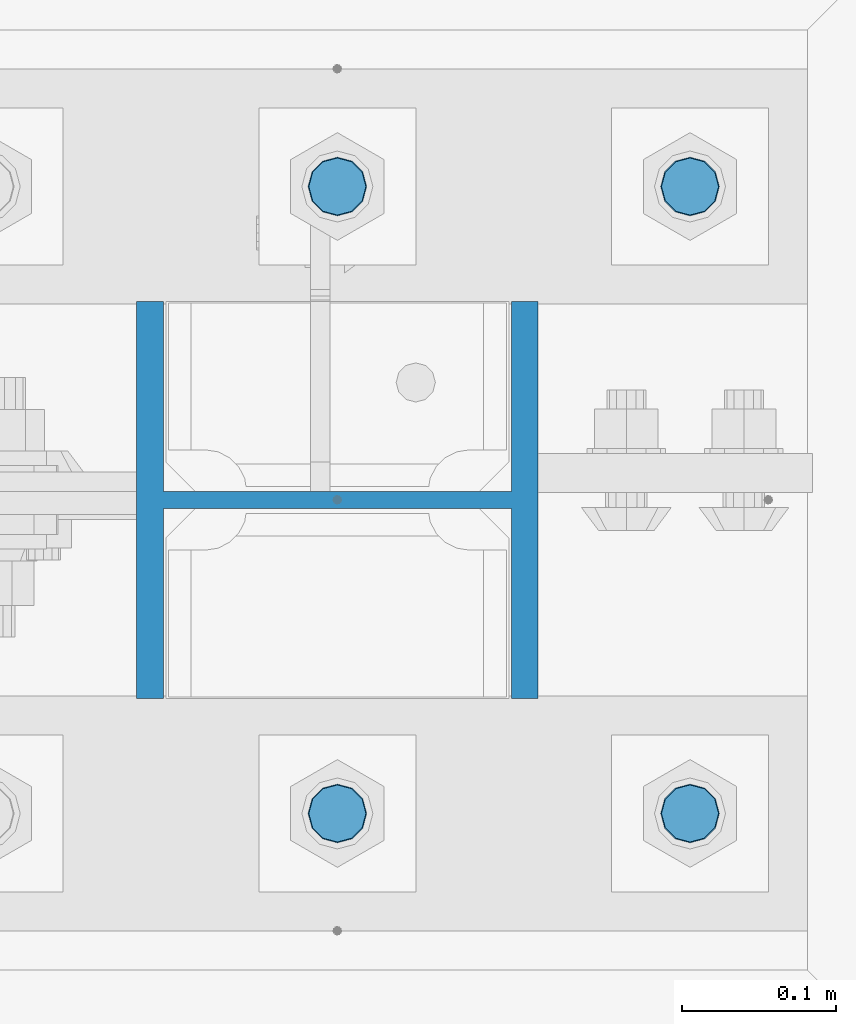
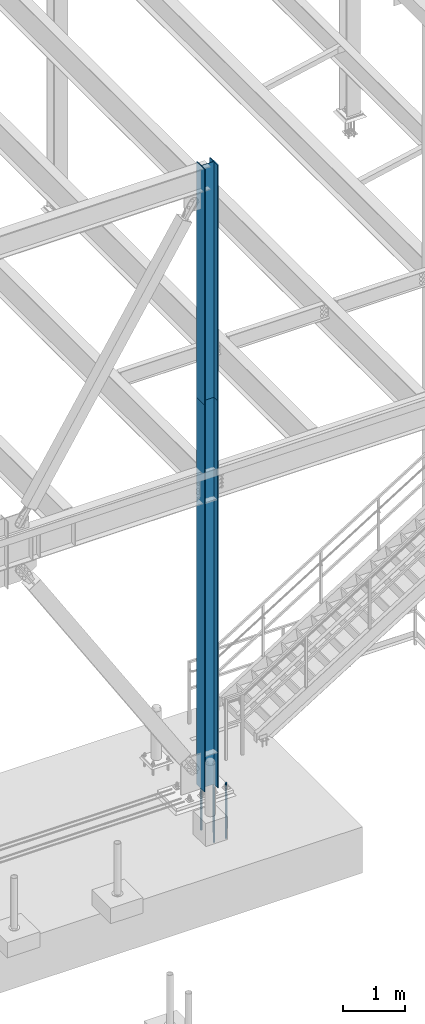
# One storey, part 1366 of 3843: 6 columns, 3 elements without a shape of their own.
"""IFC2X3 building model written with IfcOpenShell, lengths in millimetres."""

from ifc_helpers import new_model, si_unit, frame, origin_with_axes, place, context, subcontext, project, spatial, faceted_brep, material, type_object, element, aggregate, save


model = new_model("IFC2X3")

# Units and contexts
model_context = context("Model", 3, precision=1e-05, world=origin_with_axes())
body_context = subcontext(model_context, "Body", "Model", "MODEL_VIEW")
ifc_project = project(units=[si_unit("LENGTHUNIT", "METRE", prefix="MILLI"), si_unit("AREAUNIT", "SQUARE_METRE"), si_unit("VOLUMEUNIT", "CUBIC_METRE"), si_unit("MASSUNIT", "GRAM", prefix="KILO"), si_unit("TIMEUNIT", "SECOND"), si_unit("PLANEANGLEUNIT", "RADIAN"), si_unit("SOLIDANGLEUNIT", "STERADIAN"), si_unit("THERMODYNAMICTEMPERATUREUNIT", "DEGREE_CELSIUS"), si_unit("LUMINOUSINTENSITYUNIT", "LUMEN")], contexts=[model_context])

# Site, building, storey
site_placement = place(None, origin_with_axes())
site = spatial("IfcSite", under=ifc_project, at=site_placement, CompositionType="ELEMENT")
building_placement = place(site_placement, origin_with_axes())
building = spatial("IfcBuilding", under=site, at=building_placement, Name="Undefined", CompositionType="ELEMENT")
storey_placement = place(building_placement, origin_with_axes())
storey = spatial("IfcBuildingStorey", under=building, at=storey_placement, Name="Undefined", CompositionType="ELEMENT", Elevation=0.0)

# Assembly, column
assembly_1_placement = place(storey_placement, origin_with_axes())
assembly_1 = element("IfcElementAssembly", 1, at=assembly_1_placement, inside=storey, Name="CB", AssemblyPlace="NOTDEFINED", PredefinedType="RIGID_FRAME")
ifc_material_1 = material(Name="STEEL/A992")
column_type_1 = type_object("IfcColumnType", Name="W10X60", PredefinedType="NOTDEFINED")
column_1_placement = place(assembly_1_placement, frame((30480.0, 89115.9, 37795.2), z_axis=(-1.0, 0.0, 0.0), x_axis=(0.0, 0.0, 1.0)))
column_1 = element("IfcColumn", 2, at=column_1_placement, type_object=column_type_1, material=ifc_material_1, Name="COLUMN", ObjectType="W10X60", context=body_context, shape_type="Brep", body=[
    faceted_brep([(0.0, 128.587499999994, -130.174999999999), (0.0, 128.587499999994, -112.712500000001), (4673.60000000001, 128.587499999994, -112.712500000001), (4673.60000000001, 128.587499999994, -130.174999999999), (0.0, 5.55624999999418, -112.712500000001), (4673.60000000001, 5.55624999999418, -112.712500000001), (0.0, 5.55624999999418, 112.712500000001), (4673.60000000001, 5.55624999999418, 112.712500000001), (0.0, 128.587499999994, 112.712500000001), (4673.60000000001, 128.587499999994, 112.712500000001), (0.0, 128.587499999994, 130.174999999999), (4673.60000000001, 128.587499999994, 130.174999999999), (0.0, -128.587499999994, 130.174999999999), (4673.60000000001, -128.587499999994, 130.174999999999), (0.0, -128.587499999994, 112.712500000001), (4673.60000000001, -128.587499999994, 112.712500000001), (0.0, -5.55624999999418, 112.712500000001), (4673.60000000001, -5.55624999999418, 112.712500000001), (0.0, -5.55624999999418, -112.712500000001), (4673.60000000001, -5.55624999999418, -112.712500000001), (0.0, -128.587499999994, -112.712500000001), (4673.60000000001, -128.587499999994, -112.712500000001), (0.0, -128.587499999994, -130.174999999999), (4673.60000000001, -128.587499999994, -130.174999999999)], [[[0, 1, 2, 3]], [[1, 4, 5, 2]], [[4, 6, 7, 5]], [[6, 8, 9, 7]], [[8, 10, 11, 9]], [[10, 12, 13, 11]], [[12, 14, 15, 13]], [[14, 16, 17, 15]], [[16, 18, 19, 17]], [[18, 20, 21, 19]], [[20, 22, 23, 21]], [[22, 0, 3, 23]], [[5, 7, 9, 11, 13, 15, 17, 19, 21, 23, 3, 2]], [[22, 20, 18, 16, 14, 12, 10, 8, 6, 4, 1, 0]]]),
])
aggregate(assembly_1, [column_1])

assembly_2_placement = place(storey_placement, origin_with_axes())
assembly_2 = element("IfcElementAssembly", 3, at=assembly_2_placement, inside=storey, Name="COLUMN", AssemblyPlace="NOTDEFINED", PredefinedType="RIGID_FRAME")
column_2_placement = place(assembly_2_placement, frame((30480.0, 89115.9, 30022.8), z_axis=(-1.0, 0.0, 0.0), x_axis=(0.0, 0.0, 1.0)))
column_2 = element("IfcColumn", 4, at=column_2_placement, type_object=column_type_1, material=ifc_material_1, Name="COLUMN", ObjectType="W10X60", context=body_context, shape_type="Brep", body=[
    faceted_brep([(101.599999999999, 128.587499999994, -130.174999999999), (101.599999999999, 128.587499999994, -112.712500000001), (7772.4, 128.587499999994, -112.712500000001), (7772.4, 128.587499999994, -130.174999999999), (101.599999999999, 5.55624999999418, -112.712500000001), (7772.4, 5.55624999999418, -112.712500000001), (101.599999999999, 5.55624999999418, 112.712500000001), (7772.4, 5.55624999999418, 112.712500000001), (101.599999999999, 128.587499999994, 112.712500000001), (7772.4, 128.587499999994, 112.712500000001), (101.599999999999, 128.587499999994, 130.174999999999), (7772.4, 128.587499999994, 130.174999999999), (101.599999999999, -128.587499999994, 130.174999999999), (7772.4, -128.587499999994, 130.174999999999), (101.599999999999, -128.587499999994, 112.712500000001), (7772.4, -128.587499999994, 112.712500000001), (101.599999999999, -5.55624999999418, 112.712500000001), (7772.4, -5.55624999999418, 112.712500000001), (101.599999999999, -5.55624999999418, -112.712500000001), (7772.4, -5.55624999999418, -112.712500000001), (101.599999999999, -128.587499999994, -112.712500000001), (7772.4, -128.587499999994, -112.712500000001), (101.599999999999, -128.587499999994, -130.174999999999), (7772.4, -128.587499999994, -130.174999999999)], [[[0, 1, 2, 3]], [[1, 4, 5, 2]], [[4, 6, 7, 5]], [[6, 8, 9, 7]], [[8, 10, 11, 9]], [[10, 12, 13, 11]], [[12, 14, 15, 13]], [[14, 16, 17, 15]], [[16, 18, 19, 17]], [[18, 20, 21, 19]], [[20, 22, 23, 21]], [[22, 0, 3, 23]], [[5, 7, 9, 11, 13, 15, 17, 19, 21, 23, 3, 2]], [[22, 20, 18, 16, 14, 12, 10, 8, 6, 4, 1, 0]]]),
])
aggregate(assembly_2, [column_2])

# Assembly, columns
assembly_3_placement = place(storey_placement, origin_with_axes())
assembly_3 = element("IfcElementAssembly", 5, at=assembly_3_placement, inside=storey, Name="TEMPLATE", AssemblyPlace="NOTDEFINED", PredefinedType="RIGID_FRAME")
ifc_material_2 = material(Name="Undefined/F1554-GR.55")
column_type_2 = type_object("IfcColumnType", PredefinedType="NOTDEFINED")
column_3_placement = place(assembly_3_placement, frame((30708.6, 88912.7, 30022.8), z_axis=(1.0, 0.0, 0.0), x_axis=(0.0, 0.0, -1.0)))
column_3 = element("IfcColumn", 6, at=column_3_placement, type_object=column_type_2, material=ifc_material_2, Name="ANCHOR_ROD", context=body_context, shape_type="Brep", body=[
    faceted_brep([(-209.549999999999, -16.0214699700155, 9.25), (-209.549999999999, -9.25, 16.0214699700118), (-209.549999999999, 0.0, 18.5), (-209.549999999999, 9.25, 16.0214699700118), (-209.549999999999, 16.0214699700155, 9.25), (-209.549999999999, 18.5, 0.0), (-209.549999999999, 16.0214699700155, -9.25), (-209.549999999999, 9.25, -16.0214699700118), (-209.549999999999, 0.0, -18.5), (-209.549999999999, -9.25, -16.0214699700118), (-209.549999999999, -16.0214699700155, -9.25), (-209.549999999999, -18.5, 0.0), (0.0, 18.5, 0.0), (0.0, 16.0214699700118, -9.25), (0.0, 9.25, -16.0214699700155), (0.0, 0.0, -18.5), (0.0, -9.25, -16.0214699700155), (0.0, -16.0214699700118, -9.25), (0.0, -18.5, 0.0), (0.0, -16.0214699700118, 9.25), (0.0, -9.25, 16.0214699700155), (0.0, 0.0, 18.5), (0.0, 9.25, 16.0214699700155), (0.0, 16.0214699700118, 9.25), (0.0, -16.4977839420972, 9.52500000000146), (0.0, -9.52500000000146, 16.4977839420972), (0.0, 0.0, 19.0499989999989), (0.0, 9.52500000000146, 16.4977839420972), (0.0, 16.4977839420972, 9.52500000000146), (0.0, 19.0500000000029, 0.0), (0.0, 16.4977839420972, -9.52500000000146), (0.0, 9.52500000000146, -16.4977839420972), (0.0, 0.0, -19.0499989999989), (0.0, -9.52500000000146, -16.4977839420972), (0.0, -16.4977839420972, -9.52500000000146), (0.0, -19.0500000000029, 0.0), (698.5, -19.0499999999993, 0.0), (698.5, -16.4977839420935, 9.52499999999418), (698.5, -9.52500000000146, 16.4977839420899), (698.5, 0.0, 19.0500000000029), (698.5, 9.52500000000146, 16.4977839420899), (698.5, 16.4977839420935, 9.52499999999418), (698.5, 19.0499999999993, 0.0), (698.5, 16.4977839420935, -9.52499999999418), (698.5, 9.52500000000146, -16.4977839420899), (698.5, 0.0, -19.0500000000029), (698.5, -9.52500000000146, -16.4977839420899), (698.5, -16.4977839420935, -9.52499999999418), (698.5, -9.25, 16.0214699700155), (698.5, 0.0, 18.5), (698.5, 9.25, 16.0214699700155), (698.5, 16.0214699700118, 9.25), (698.5, 18.5, 0.0), (698.5, 16.0214699700118, -9.25), (698.5, 9.25, -16.0214699700155), (698.5, 0.0, -18.5), (698.5, -9.25, -16.0214699700155), (698.5, -16.0214699700118, -9.25), (698.5, -18.5, 0.0), (698.5, -16.0214699700118, 9.25), (889.0, -9.25, -16.0214699700155), (889.0, 0.0, -18.5), (889.0, 9.25, -16.0214699700155), (889.0, 16.0214699700118, -9.25), (889.0, 18.5, 0.0), (889.0, 16.0214699700118, 9.25), (889.0, 9.25, 16.0214699700155), (889.0, 0.0, 18.5), (889.0, -9.25, 16.0214699700155), (889.0, -16.0214699700118, 9.25), (889.0, -18.5, 0.0), (889.0, -16.0214699700118, -9.25)], [[[0, 1, 2, 3, 4, 5, 6, 7, 8, 9, 10, 11]], [[6, 5, 12, 13]], [[7, 6, 13, 14]], [[8, 7, 14, 15]], [[9, 8, 15, 16]], [[10, 9, 16, 17]], [[11, 10, 17, 18]], [[0, 11, 18, 19]], [[1, 0, 19, 20]], [[2, 1, 20, 21]], [[3, 2, 21, 22]], [[4, 3, 22, 23]], [[5, 4, 23, 12]], [[24, 25, 26, 27, 28, 29, 30, 31, 32, 33, 34, 35], [22, 21, 20, 19, 18, 17, 16, 15, 14, 13, 12, 23]], [[24, 35, 36, 37]], [[25, 24, 37, 38]], [[26, 25, 38, 39]], [[27, 26, 39, 40]], [[28, 27, 40, 41]], [[29, 28, 41, 42]], [[30, 29, 42, 43]], [[31, 30, 43, 44]], [[32, 31, 44, 45]], [[33, 32, 45, 46]], [[34, 33, 46, 47]], [[35, 34, 47, 36]], [[46, 45, 44, 43, 42, 41, 40, 39, 38, 37, 36, 47], [48, 49, 50, 51, 52, 53, 54, 55, 56, 57, 58, 59]], [[60, 61, 62, 63, 64, 65, 66, 67, 68, 69, 70, 71]], [[68, 67, 49, 48]], [[69, 68, 48, 59]], [[70, 69, 59, 58]], [[71, 70, 58, 57]], [[60, 71, 57, 56]], [[61, 60, 56, 55]], [[62, 61, 55, 54]], [[63, 62, 54, 53]], [[64, 63, 53, 52]], [[65, 64, 52, 51]], [[66, 65, 51, 50]], [[67, 66, 50, 49]]]),
])
column_4_placement = place(assembly_3_placement, frame((30708.6, 89319.1, 30022.8), z_axis=(-1.0, 0.0, 0.0), x_axis=(0.0, 0.0, -1.0)))
column_4 = element("IfcColumn", 7, at=column_4_placement, type_object=column_type_2, material=ifc_material_2, Name="ANCHOR_ROD", context=body_context, shape_type="Brep", body=[
    faceted_brep([(-209.549999999999, -16.0214699700155, 9.25), (-209.549999999999, -9.25, 16.0214699700118), (-209.549999999999, 0.0, 18.5), (-209.549999999999, 9.25, 16.0214699700118), (-209.549999999999, 16.0214699700155, 9.25), (-209.549999999999, 18.5, 0.0), (-209.549999999999, 16.0214699700155, -9.25), (-209.549999999999, 9.25, -16.0214699700118), (-209.549999999999, 0.0, -18.5), (-209.549999999999, -9.25, -16.0214699700118), (-209.549999999999, -16.0214699700155, -9.25), (-209.549999999999, -18.5, 0.0), (0.0, 18.5, 0.0), (0.0, 16.0214699700118, -9.25), (0.0, 9.25, -16.0214699700155), (0.0, 0.0, -18.5), (0.0, -9.25, -16.0214699700155), (0.0, -16.0214699700118, -9.25), (0.0, -18.5, 0.0), (0.0, -16.0214699700118, 9.25), (0.0, -9.25, 16.0214699700155), (0.0, 0.0, 18.5), (0.0, 9.25, 16.0214699700155), (0.0, 16.0214699700118, 9.25), (0.0, -16.4977839420972, 9.52500000000146), (0.0, -9.52500000000146, 16.4977839420972), (0.0, 0.0, 19.0499989999989), (0.0, 9.52500000000146, 16.4977839420972), (0.0, 16.4977839420972, 9.52500000000146), (0.0, 19.0500000000029, 0.0), (0.0, 16.4977839420972, -9.52500000000146), (0.0, 9.52500000000146, -16.4977839420972), (0.0, 0.0, -19.0499989999989), (0.0, -9.52500000000146, -16.4977839420972), (0.0, -16.4977839420972, -9.52500000000146), (0.0, -19.0500000000029, 0.0), (698.5, -19.0499999999993, 0.0), (698.5, -16.4977839420935, 9.52499999999418), (698.5, -9.52500000000146, 16.4977839420899), (698.5, 0.0, 19.0500000000029), (698.5, 9.52500000000146, 16.4977839420899), (698.5, 16.4977839420935, 9.52499999999418), (698.5, 19.0499999999993, 0.0), (698.5, 16.4977839420935, -9.52499999999418), (698.5, 9.52500000000146, -16.4977839420899), (698.5, 0.0, -19.0500000000029), (698.5, -9.52500000000146, -16.4977839420899), (698.5, -16.4977839420935, -9.52499999999418), (698.5, -9.25, 16.0214699700155), (698.5, 0.0, 18.5), (698.5, 9.25, 16.0214699700155), (698.5, 16.0214699700118, 9.25), (698.5, 18.5, 0.0), (698.5, 16.0214699700118, -9.25), (698.5, 9.25, -16.0214699700155), (698.5, 0.0, -18.5), (698.5, -9.25, -16.0214699700155), (698.5, -16.0214699700118, -9.25), (698.5, -18.5, 0.0), (698.5, -16.0214699700118, 9.25), (889.0, -9.25, -16.0214699700155), (889.0, 0.0, -18.5), (889.0, 9.25, -16.0214699700155), (889.0, 16.0214699700118, -9.25), (889.0, 18.5, 0.0), (889.0, 16.0214699700118, 9.25), (889.0, 9.25, 16.0214699700155), (889.0, 0.0, 18.5), (889.0, -9.25, 16.0214699700155), (889.0, -16.0214699700118, 9.25), (889.0, -18.5, 0.0), (889.0, -16.0214699700118, -9.25)], [[[0, 1, 2, 3, 4, 5, 6, 7, 8, 9, 10, 11]], [[6, 5, 12, 13]], [[7, 6, 13, 14]], [[8, 7, 14, 15]], [[9, 8, 15, 16]], [[10, 9, 16, 17]], [[11, 10, 17, 18]], [[0, 11, 18, 19]], [[1, 0, 19, 20]], [[2, 1, 20, 21]], [[3, 2, 21, 22]], [[4, 3, 22, 23]], [[5, 4, 23, 12]], [[24, 25, 26, 27, 28, 29, 30, 31, 32, 33, 34, 35], [22, 21, 20, 19, 18, 17, 16, 15, 14, 13, 12, 23]], [[24, 35, 36, 37]], [[25, 24, 37, 38]], [[26, 25, 38, 39]], [[27, 26, 39, 40]], [[28, 27, 40, 41]], [[29, 28, 41, 42]], [[30, 29, 42, 43]], [[31, 30, 43, 44]], [[32, 31, 44, 45]], [[33, 32, 45, 46]], [[34, 33, 46, 47]], [[35, 34, 47, 36]], [[46, 45, 44, 43, 42, 41, 40, 39, 38, 37, 36, 47], [48, 49, 50, 51, 52, 53, 54, 55, 56, 57, 58, 59]], [[60, 61, 62, 63, 64, 65, 66, 67, 68, 69, 70, 71]], [[68, 67, 49, 48]], [[69, 68, 48, 59]], [[70, 69, 59, 58]], [[71, 70, 58, 57]], [[60, 71, 57, 56]], [[61, 60, 56, 55]], [[62, 61, 55, 54]], [[63, 62, 54, 53]], [[64, 63, 53, 52]], [[65, 64, 52, 51]], [[66, 65, 51, 50]], [[67, 66, 50, 49]]]),
])
column_5_placement = place(assembly_3_placement, frame((30480.0, 88912.7, 30022.8), z_axis=(1.0, 0.0, 0.0), x_axis=(0.0, 0.0, -1.0)))
column_5 = element("IfcColumn", 8, at=column_5_placement, type_object=column_type_2, material=ifc_material_2, Name="ANCHOR_ROD", context=body_context, shape_type="Brep", body=[
    faceted_brep([(-209.549999999999, -16.0214699700155, 9.25), (-209.549999999999, -9.25, 16.0214699700118), (-209.549999999999, 0.0, 18.5), (-209.549999999999, 9.25, 16.0214699700118), (-209.549999999999, 16.0214699700155, 9.25), (-209.549999999999, 18.5, 0.0), (-209.549999999999, 16.0214699700155, -9.25), (-209.549999999999, 9.25, -16.0214699700118), (-209.549999999999, 0.0, -18.5), (-209.549999999999, -9.25, -16.0214699700118), (-209.549999999999, -16.0214699700155, -9.25), (-209.549999999999, -18.5, 0.0), (0.0, 18.5, 0.0), (0.0, 16.0214699700118, -9.25), (0.0, 9.25, -16.0214699700155), (0.0, 0.0, -18.5), (0.0, -9.25, -16.0214699700155), (0.0, -16.0214699700118, -9.25), (0.0, -18.5, 0.0), (0.0, -16.0214699700118, 9.25), (0.0, -9.25, 16.0214699700155), (0.0, 0.0, 18.5), (0.0, 9.25, 16.0214699700155), (0.0, 16.0214699700118, 9.25), (0.0, -16.4977839420972, 9.52500000000146), (0.0, -9.52500000000146, 16.4977839420972), (0.0, 0.0, 19.0499989999989), (0.0, 9.52500000000146, 16.4977839420972), (0.0, 16.4977839420972, 9.52500000000146), (0.0, 19.0500000000029, 0.0), (0.0, 16.4977839420972, -9.52500000000146), (0.0, 9.52500000000146, -16.4977839420972), (0.0, 0.0, -19.0499989999989), (0.0, -9.52500000000146, -16.4977839420972), (0.0, -16.4977839420972, -9.52500000000146), (0.0, -19.0500000000029, 0.0), (698.5, -19.0499999999993, 0.0), (698.5, -16.4977839420935, 9.52499999999418), (698.5, -9.52500000000146, 16.4977839420899), (698.5, 0.0, 19.0500000000029), (698.5, 9.52500000000146, 16.4977839420899), (698.5, 16.4977839420935, 9.52499999999418), (698.5, 19.0499999999993, 0.0), (698.5, 16.4977839420935, -9.52499999999418), (698.5, 9.52500000000146, -16.4977839420899), (698.5, 0.0, -19.0500000000029), (698.5, -9.52500000000146, -16.4977839420899), (698.5, -16.4977839420935, -9.52499999999418), (698.5, -9.25, 16.0214699700155), (698.5, 0.0, 18.5), (698.5, 9.25, 16.0214699700155), (698.5, 16.0214699700118, 9.25), (698.5, 18.5, 0.0), (698.5, 16.0214699700118, -9.25), (698.5, 9.25, -16.0214699700155), (698.5, 0.0, -18.5), (698.5, -9.25, -16.0214699700155), (698.5, -16.0214699700118, -9.25), (698.5, -18.5, 0.0), (698.5, -16.0214699700118, 9.25), (889.0, -9.25, -16.0214699700155), (889.0, 0.0, -18.5), (889.0, 9.25, -16.0214699700155), (889.0, 16.0214699700118, -9.25), (889.0, 18.5, 0.0), (889.0, 16.0214699700118, 9.25), (889.0, 9.25, 16.0214699700155), (889.0, 0.0, 18.5), (889.0, -9.25, 16.0214699700155), (889.0, -16.0214699700118, 9.25), (889.0, -18.5, 0.0), (889.0, -16.0214699700118, -9.25)], [[[0, 1, 2, 3, 4, 5, 6, 7, 8, 9, 10, 11]], [[6, 5, 12, 13]], [[7, 6, 13, 14]], [[8, 7, 14, 15]], [[9, 8, 15, 16]], [[10, 9, 16, 17]], [[11, 10, 17, 18]], [[0, 11, 18, 19]], [[1, 0, 19, 20]], [[2, 1, 20, 21]], [[3, 2, 21, 22]], [[4, 3, 22, 23]], [[5, 4, 23, 12]], [[24, 25, 26, 27, 28, 29, 30, 31, 32, 33, 34, 35], [22, 21, 20, 19, 18, 17, 16, 15, 14, 13, 12, 23]], [[24, 35, 36, 37]], [[25, 24, 37, 38]], [[26, 25, 38, 39]], [[27, 26, 39, 40]], [[28, 27, 40, 41]], [[29, 28, 41, 42]], [[30, 29, 42, 43]], [[31, 30, 43, 44]], [[32, 31, 44, 45]], [[33, 32, 45, 46]], [[34, 33, 46, 47]], [[35, 34, 47, 36]], [[46, 45, 44, 43, 42, 41, 40, 39, 38, 37, 36, 47], [48, 49, 50, 51, 52, 53, 54, 55, 56, 57, 58, 59]], [[60, 61, 62, 63, 64, 65, 66, 67, 68, 69, 70, 71]], [[68, 67, 49, 48]], [[69, 68, 48, 59]], [[70, 69, 59, 58]], [[71, 70, 58, 57]], [[60, 71, 57, 56]], [[61, 60, 56, 55]], [[62, 61, 55, 54]], [[63, 62, 54, 53]], [[64, 63, 53, 52]], [[65, 64, 52, 51]], [[66, 65, 51, 50]], [[67, 66, 50, 49]]]),
])
column_6_placement = place(assembly_3_placement, frame((30480.0, 89319.1, 30022.8), z_axis=(-1.0, 0.0, 0.0), x_axis=(0.0, 0.0, -1.0)))
column_6 = element("IfcColumn", 9, at=column_6_placement, type_object=column_type_2, material=ifc_material_2, Name="ANCHOR_ROD", context=body_context, shape_type="Brep", body=[
    faceted_brep([(-209.549999999999, -16.0214699700155, 9.25), (-209.549999999999, -9.25, 16.0214699700118), (-209.549999999999, 0.0, 18.5), (-209.549999999999, 9.25, 16.0214699700118), (-209.549999999999, 16.0214699700155, 9.25), (-209.549999999999, 18.5, 0.0), (-209.549999999999, 16.0214699700155, -9.25), (-209.549999999999, 9.25, -16.0214699700118), (-209.549999999999, 0.0, -18.5), (-209.549999999999, -9.25, -16.0214699700118), (-209.549999999999, -16.0214699700155, -9.25), (-209.549999999999, -18.5, 0.0), (0.0, 18.5, 0.0), (0.0, 16.0214699700118, -9.25), (0.0, 9.25, -16.0214699700155), (0.0, 0.0, -18.5), (0.0, -9.25, -16.0214699700155), (0.0, -16.0214699700118, -9.25), (0.0, -18.5, 0.0), (0.0, -16.0214699700118, 9.25), (0.0, -9.25, 16.0214699700155), (0.0, 0.0, 18.5), (0.0, 9.25, 16.0214699700155), (0.0, 16.0214699700118, 9.25), (0.0, -16.4977839420972, 9.52500000000146), (0.0, -9.52500000000146, 16.4977839420972), (0.0, 0.0, 19.0499989999989), (0.0, 9.52500000000146, 16.4977839420972), (0.0, 16.4977839420972, 9.52500000000146), (0.0, 19.0500000000029, 0.0), (0.0, 16.4977839420972, -9.52500000000146), (0.0, 9.52500000000146, -16.4977839420972), (0.0, 0.0, -19.0499989999989), (0.0, -9.52500000000146, -16.4977839420972), (0.0, -16.4977839420972, -9.52500000000146), (0.0, -19.0500000000029, 0.0), (698.5, -19.0499999999993, 0.0), (698.5, -16.4977839420935, 9.52499999999418), (698.5, -9.52500000000146, 16.4977839420899), (698.5, 0.0, 19.0500000000029), (698.5, 9.52500000000146, 16.4977839420899), (698.5, 16.4977839420935, 9.52499999999418), (698.5, 19.0499999999993, 0.0), (698.5, 16.4977839420935, -9.52499999999418), (698.5, 9.52500000000146, -16.4977839420899), (698.5, 0.0, -19.0500000000029), (698.5, -9.52500000000146, -16.4977839420899), (698.5, -16.4977839420935, -9.52499999999418), (698.5, -9.25, 16.0214699700155), (698.5, 0.0, 18.5), (698.5, 9.25, 16.0214699700155), (698.5, 16.0214699700118, 9.25), (698.5, 18.5, 0.0), (698.5, 16.0214699700118, -9.25), (698.5, 9.25, -16.0214699700155), (698.5, 0.0, -18.5), (698.5, -9.25, -16.0214699700155), (698.5, -16.0214699700118, -9.25), (698.5, -18.5, 0.0), (698.5, -16.0214699700118, 9.25), (889.0, -9.25, -16.0214699700155), (889.0, 0.0, -18.5), (889.0, 9.25, -16.0214699700155), (889.0, 16.0214699700118, -9.25), (889.0, 18.5, 0.0), (889.0, 16.0214699700118, 9.25), (889.0, 9.25, 16.0214699700155), (889.0, 0.0, 18.5), (889.0, -9.25, 16.0214699700155), (889.0, -16.0214699700118, 9.25), (889.0, -18.5, 0.0), (889.0, -16.0214699700118, -9.25)], [[[0, 1, 2, 3, 4, 5, 6, 7, 8, 9, 10, 11]], [[6, 5, 12, 13]], [[7, 6, 13, 14]], [[8, 7, 14, 15]], [[9, 8, 15, 16]], [[10, 9, 16, 17]], [[11, 10, 17, 18]], [[0, 11, 18, 19]], [[1, 0, 19, 20]], [[2, 1, 20, 21]], [[3, 2, 21, 22]], [[4, 3, 22, 23]], [[5, 4, 23, 12]], [[24, 25, 26, 27, 28, 29, 30, 31, 32, 33, 34, 35], [22, 21, 20, 19, 18, 17, 16, 15, 14, 13, 12, 23]], [[24, 35, 36, 37]], [[25, 24, 37, 38]], [[26, 25, 38, 39]], [[27, 26, 39, 40]], [[28, 27, 40, 41]], [[29, 28, 41, 42]], [[30, 29, 42, 43]], [[31, 30, 43, 44]], [[32, 31, 44, 45]], [[33, 32, 45, 46]], [[34, 33, 46, 47]], [[35, 34, 47, 36]], [[46, 45, 44, 43, 42, 41, 40, 39, 38, 37, 36, 47], [48, 49, 50, 51, 52, 53, 54, 55, 56, 57, 58, 59]], [[60, 61, 62, 63, 64, 65, 66, 67, 68, 69, 70, 71]], [[68, 67, 49, 48]], [[69, 68, 48, 59]], [[70, 69, 59, 58]], [[71, 70, 58, 57]], [[60, 71, 57, 56]], [[61, 60, 56, 55]], [[62, 61, 55, 54]], [[63, 62, 54, 53]], [[64, 63, 53, 52]], [[65, 64, 52, 51]], [[66, 65, 51, 50]], [[67, 66, 50, 49]]]),
])
aggregate(assembly_3, [column_3, column_4, column_5, column_6])

save(model, "model.ifc")
